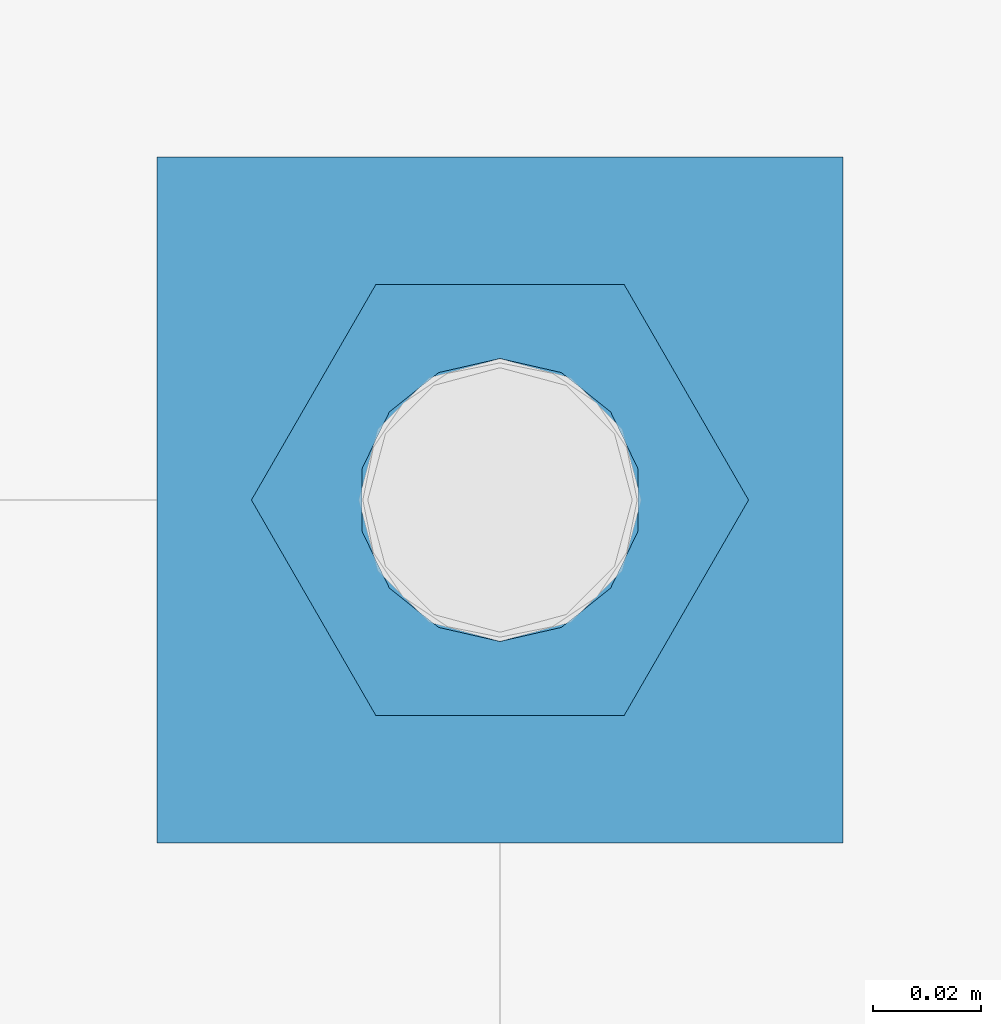
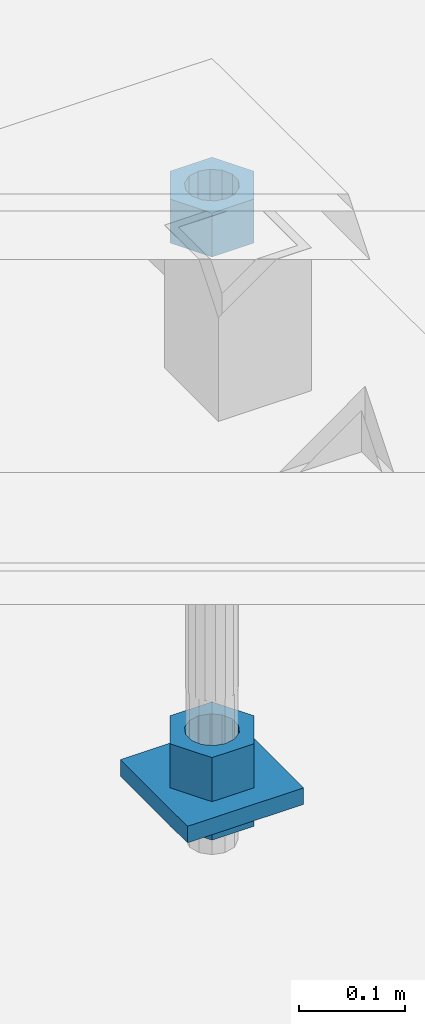
# One storey, part 2682 of 3843: 4 beams, 1 element without a shape of its own.
"""IFC2X3 building model written with IfcOpenShell, lengths in millimetres."""

from ifc_helpers import new_model, si_unit, frame, origin_with_axes, place, context, subcontext, project, spatial, faceted_brep, material, type_object, element, aggregate, save


model = new_model("IFC2X3")

# Units and contexts
model_context = context("Model", 3, precision=1e-05, world=origin_with_axes())
body_context = subcontext(model_context, "Body", "Model", "MODEL_VIEW")
ifc_project = project(units=[si_unit("LENGTHUNIT", "METRE", prefix="MILLI"), si_unit("AREAUNIT", "SQUARE_METRE"), si_unit("VOLUMEUNIT", "CUBIC_METRE"), si_unit("MASSUNIT", "GRAM", prefix="KILO"), si_unit("TIMEUNIT", "SECOND"), si_unit("PLANEANGLEUNIT", "RADIAN"), si_unit("SOLIDANGLEUNIT", "STERADIAN"), si_unit("THERMODYNAMICTEMPERATUREUNIT", "DEGREE_CELSIUS"), si_unit("LUMINOUSINTENSITYUNIT", "LUMEN")], contexts=[model_context])

# Site, building, storey
site_placement = place(None, origin_with_axes())
site = spatial("IfcSite", under=ifc_project, at=site_placement, CompositionType="ELEMENT")
building_placement = place(site_placement, origin_with_axes())
building = spatial("IfcBuilding", under=site, at=building_placement, Name="Undefined", CompositionType="ELEMENT")
storey_placement = place(building_placement, origin_with_axes())
storey = spatial("IfcBuildingStorey", under=building, at=storey_placement, Name="Undefined", CompositionType="ELEMENT", Elevation=0.0)

# Assembly, beams
assembly_placement = place(storey_placement, origin_with_axes())
assembly = element("IfcElementAssembly", 1, at=assembly_placement, inside=storey, Name="TEMPLATE", AssemblyPlace="NOTDEFINED", PredefinedType="RIGID_FRAME")
ifc_material_1 = material(Name="STEEL/A572-50")
beam_type_1 = type_object("IfcBeamType", PredefinedType="NOTDEFINED")
beam_1_placement = place(assembly_placement, frame((119227.6, 29654.5000015259, 29244.925), z_axis=(1.0, 0.0, 0.0), x_axis=(0.0, 1.0, 0.0)))
beam_1 = element("IfcBeam", 2, at=beam_1_placement, type_object=beam_type_1, material=ifc_material_1, Name="WASHER_PLATE", context=body_context, shape_type="Brep", body=[
    faceted_brep([(0.0, 9.52500000000146, -63.5), (0.0, 9.52500000000146, 63.5), (127.0, 9.52500000000146, 63.5), (127.0, 9.52500000000146, -63.5), (0.0, -9.52500000000146, 63.5), (127.0, -9.52500000000146, 63.5), (0.0, -9.52500000000146, -63.5), (127.0, -9.52500000000146, -63.5)], [[[0, 1, 2, 3]], [[1, 4, 5, 2]], [[4, 6, 7, 5]], [[6, 0, 3, 7]], [[5, 7, 3, 2]], [[6, 4, 1, 0]]]),
])
ifc_material_2 = material(Name="STEEL/A36")
beam_type_2 = type_object("IfcBeamType", Name="2_HALF_NUT", PredefinedType="NOTDEFINED")
beam_2_placement = place(assembly_placement, frame((119227.6, 29718.0000015259, 29235.4), z_axis=(0.0, 1.0, 0.0), x_axis=(0.0, 0.0, -1.0)))
beam_2 = element("IfcBeam", 3, at=beam_2_placement, type_object=beam_type_2, material=ifc_material_2, Name="NUT", ObjectType="2_HALF_NUT", context=body_context, shape_type="Brep", body=[
    faceted_brep([(0.0, -46.0369987487793, 0.0), (0.0, -23.0184993743896, -39.869213104248), (25.4000000000015, -23.0184993743896, -39.869213104248), (25.4000000000015, -46.0369987487793, 0.0), (0.0, 23.0184993743896, -39.869213104248), (25.4000000000015, 23.0184993743896, -39.869213104248), (0.0, 46.0369987487793, 0.0), (25.4000000000015, 46.0369987487793, 0.0), (0.0, 23.0184993743896, 39.869213104248), (25.4000000000015, 23.0184993743896, 39.869213104248), (0.0, -23.0184993743896, 39.869213104248), (25.4000000000015, -23.0184993743896, 39.869213104248), (0.0, 0.0, 26.1940002441406), (0.0, 11.3650617044477, 23.5999013092805), (25.4000000000015, 11.3650617044477, 23.5999013092805), (25.4000000000015, 0.0, 26.1940002441406), (0.0, 20.4791109456419, 16.3316083006721), (25.4000000000015, 20.4791109456419, 16.3316083006721), (0.0, 25.5370200498292, 5.82867859874386), (25.4000000000015, 25.5370200498292, 5.82867859874386), (0.0, 25.5370200498292, -5.82867859874386), (25.4000000000015, 25.5370200498292, -5.82867859874386), (0.0, 20.4791109456419, -16.3316083006721), (25.4000000000015, 20.4791109456419, -16.3316083006721), (0.0, 11.3650617044477, -23.5999013092805), (25.4000000000015, 11.3650617044477, -23.5999013092805), (0.0, 0.0, -26.1940002441406), (25.4000000000015, 0.0, -26.1940002441406), (0.0, -11.3650617044477, -23.5999013092805), (25.4000000000015, -11.3650617044477, -23.5999013092805), (0.0, -20.4791109456419, -16.3316083006721), (25.4000000000015, -20.4791109456419, -16.3316083006721), (0.0, -25.5370200498292, -5.82867859874386), (25.4000000000015, -25.5370200498292, -5.82867859874386), (0.0, -25.5370200498292, 5.82867859874386), (25.4000000000015, -25.5370200498292, 5.82867859874386), (0.0, -20.4791109456419, 16.3316083006721), (25.4000000000015, -20.4791109456419, 16.3316083006721), (0.0, -11.3650617044477, 23.5999013092805), (25.4000000000015, -11.3650617044477, 23.5999013092805)], [[[0, 1, 2, 3]], [[1, 4, 5, 2]], [[4, 6, 7, 5]], [[6, 8, 9, 7]], [[8, 10, 11, 9]], [[10, 0, 3, 11]], [[12, 13, 14, 15]], [[13, 16, 17, 14]], [[16, 18, 19, 17]], [[18, 20, 21, 19]], [[20, 22, 23, 21]], [[22, 24, 25, 23]], [[24, 26, 27, 25]], [[26, 28, 29, 27]], [[28, 30, 31, 29]], [[30, 32, 33, 31]], [[32, 34, 35, 33]], [[34, 36, 37, 35]], [[36, 38, 39, 37]], [[38, 12, 15, 39]], [[5, 7, 9, 11, 3, 2], [17, 19, 21, 23, 25, 27, 29, 31, 33, 35, 37, 39, 15, 14]], [[10, 8, 6, 4, 1, 0], [38, 36, 34, 32, 30, 28, 26, 24, 22, 20, 18, 16, 13, 12]]]),
])
beam_type_3 = type_object("IfcBeamType", Name="2_HEAVY_HEX_NUT", PredefinedType="NOTDEFINED")
beam_3_placement = place(assembly_placement, frame((119227.6, 29718.0000015259, 29933.9), z_axis=(0.0, 1.0, 0.0), x_axis=(0.0, 0.0, -1.0)))
beam_3 = element("IfcBeam", 4, at=beam_3_placement, type_object=beam_type_3, material=ifc_material_2, Name="NUT", ObjectType="2_HEAVY_HEX_NUT", context=body_context, shape_type="Brep", body=[
    faceted_brep([(0.0, -46.0369987487793, 0.0), (0.0, -23.0184993743896, -39.869213104248), (50.7999999999993, -23.0184993743896, -39.869213104248), (50.7999999999993, -46.0369987487793, 0.0), (0.0, 23.0184993743896, -39.869213104248), (50.7999999999993, 23.0184993743896, -39.869213104248), (0.0, 46.0369987487793, 0.0), (50.7999999999993, 46.0369987487793, 0.0), (0.0, 23.0184993743896, 39.869213104248), (50.7999999999993, 23.0184993743896, 39.869213104248), (0.0, -23.0184993743896, 39.869213104248), (50.7999999999993, -23.0184993743896, 39.869213104248), (0.0, 0.0, 26.1940002441406), (0.0, 11.3650617044477, 23.5999013092805), (50.7999999999993, 11.3650617044477, 23.5999013092805), (50.7999999999993, 0.0, 26.1940002441406), (0.0, 20.4791109456419, 16.3316083006721), (50.7999999999993, 20.4791109456419, 16.3316083006721), (0.0, 25.5370200498292, 5.82867859874386), (50.7999999999993, 25.5370200498292, 5.82867859874386), (0.0, 25.5370200498292, -5.82867859874386), (50.7999999999993, 25.5370200498292, -5.82867859874386), (0.0, 20.4791109456419, -16.3316083006721), (50.7999999999993, 20.4791109456419, -16.3316083006721), (0.0, 11.3650617044477, -23.5999013092805), (50.7999999999993, 11.3650617044477, -23.5999013092805), (0.0, 0.0, -26.1940002441406), (50.7999999999993, 0.0, -26.1940002441406), (0.0, -11.3650617044477, -23.5999013092805), (50.7999999999993, -11.3650617044477, -23.5999013092805), (0.0, -20.4791109456419, -16.3316083006721), (50.7999999999993, -20.4791109456419, -16.3316083006721), (0.0, -25.5370200498292, -5.82867859874386), (50.7999999999993, -25.5370200498292, -5.82867859874386), (0.0, -25.5370200498292, 5.82867859874386), (50.7999999999993, -25.5370200498292, 5.82867859874386), (0.0, -20.4791109456419, 16.3316083006721), (50.7999999999993, -20.4791109456419, 16.3316083006721), (0.0, -11.3650617044477, 23.5999013092805), (50.7999999999993, -11.3650617044477, 23.5999013092805)], [[[0, 1, 2, 3]], [[1, 4, 5, 2]], [[4, 6, 7, 5]], [[6, 8, 9, 7]], [[8, 10, 11, 9]], [[10, 0, 3, 11]], [[12, 13, 14, 15]], [[13, 16, 17, 14]], [[16, 18, 19, 17]], [[18, 20, 21, 19]], [[20, 22, 23, 21]], [[22, 24, 25, 23]], [[24, 26, 27, 25]], [[26, 28, 29, 27]], [[28, 30, 31, 29]], [[30, 32, 33, 31]], [[32, 34, 35, 33]], [[34, 36, 37, 35]], [[36, 38, 39, 37]], [[38, 12, 15, 39]], [[5, 7, 9, 11, 3, 2], [17, 19, 21, 23, 25, 27, 29, 31, 33, 35, 37, 39, 15, 14]], [[10, 8, 6, 4, 1, 0], [38, 36, 34, 32, 30, 28, 26, 24, 22, 20, 18, 16, 13, 12]]]),
])
beam_4_placement = place(assembly_placement, frame((119227.6, 29718.0000015259, 29305.25), z_axis=(0.0, 1.0, 0.0), x_axis=(0.0, 0.0, -1.0)))
beam_4 = element("IfcBeam", 5, at=beam_4_placement, type_object=beam_type_3, material=ifc_material_2, Name="NUT", ObjectType="2_HEAVY_HEX_NUT", context=body_context, shape_type="Brep", body=[
    faceted_brep([(0.0, -46.0369987487793, 0.0), (0.0, -23.0184993743896, -39.869213104248), (50.7999999999993, -23.0184993743896, -39.869213104248), (50.7999999999993, -46.0369987487793, 0.0), (0.0, 23.0184993743896, -39.869213104248), (50.7999999999993, 23.0184993743896, -39.869213104248), (0.0, 46.0369987487793, 0.0), (50.7999999999993, 46.0369987487793, 0.0), (0.0, 23.0184993743896, 39.869213104248), (50.7999999999993, 23.0184993743896, 39.869213104248), (0.0, -23.0184993743896, 39.869213104248), (50.7999999999993, -23.0184993743896, 39.869213104248), (0.0, 0.0, 26.1940002441406), (0.0, 11.3650617044477, 23.5999013092805), (50.7999999999993, 11.3650617044477, 23.5999013092805), (50.7999999999993, 0.0, 26.1940002441406), (0.0, 20.4791109456419, 16.3316083006721), (50.7999999999993, 20.4791109456419, 16.3316083006721), (0.0, 25.5370200498292, 5.82867859874386), (50.7999999999993, 25.5370200498292, 5.82867859874386), (0.0, 25.5370200498292, -5.82867859874386), (50.7999999999993, 25.5370200498292, -5.82867859874386), (0.0, 20.4791109456419, -16.3316083006721), (50.7999999999993, 20.4791109456419, -16.3316083006721), (0.0, 11.3650617044477, -23.5999013092805), (50.7999999999993, 11.3650617044477, -23.5999013092805), (0.0, 0.0, -26.1940002441406), (50.7999999999993, 0.0, -26.1940002441406), (0.0, -11.3650617044477, -23.5999013092805), (50.7999999999993, -11.3650617044477, -23.5999013092805), (0.0, -20.4791109456419, -16.3316083006721), (50.7999999999993, -20.4791109456419, -16.3316083006721), (0.0, -25.5370200498292, -5.82867859874386), (50.7999999999993, -25.5370200498292, -5.82867859874386), (0.0, -25.5370200498292, 5.82867859874386), (50.7999999999993, -25.5370200498292, 5.82867859874386), (0.0, -20.4791109456419, 16.3316083006721), (50.7999999999993, -20.4791109456419, 16.3316083006721), (0.0, -11.3650617044477, 23.5999013092805), (50.7999999999993, -11.3650617044477, 23.5999013092805)], [[[0, 1, 2, 3]], [[1, 4, 5, 2]], [[4, 6, 7, 5]], [[6, 8, 9, 7]], [[8, 10, 11, 9]], [[10, 0, 3, 11]], [[12, 13, 14, 15]], [[13, 16, 17, 14]], [[16, 18, 19, 17]], [[18, 20, 21, 19]], [[20, 22, 23, 21]], [[22, 24, 25, 23]], [[24, 26, 27, 25]], [[26, 28, 29, 27]], [[28, 30, 31, 29]], [[30, 32, 33, 31]], [[32, 34, 35, 33]], [[34, 36, 37, 35]], [[36, 38, 39, 37]], [[38, 12, 15, 39]], [[5, 7, 9, 11, 3, 2], [17, 19, 21, 23, 25, 27, 29, 31, 33, 35, 37, 39, 15, 14]], [[10, 8, 6, 4, 1, 0], [38, 36, 34, 32, 30, 28, 26, 24, 22, 20, 18, 16, 13, 12]]]),
])
aggregate(assembly, [beam_3, beam_4, beam_2, beam_1])

save(model, "model.ifc")
